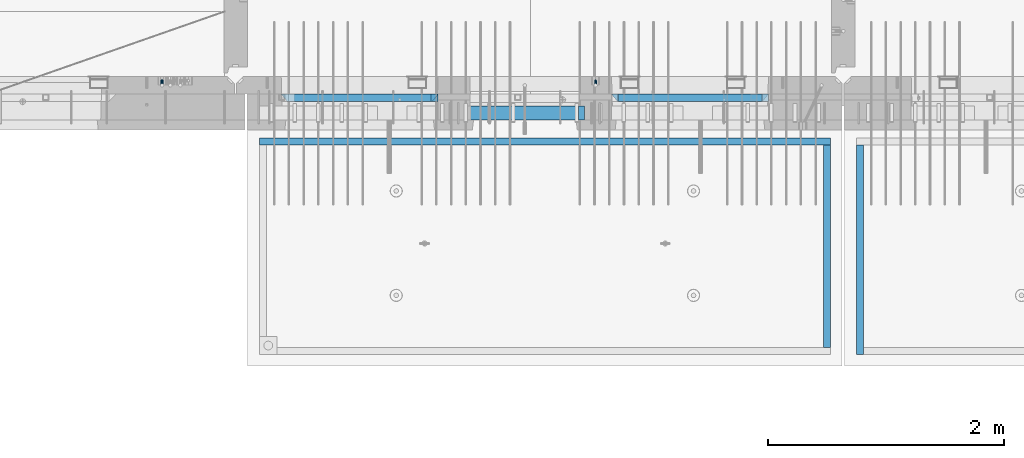
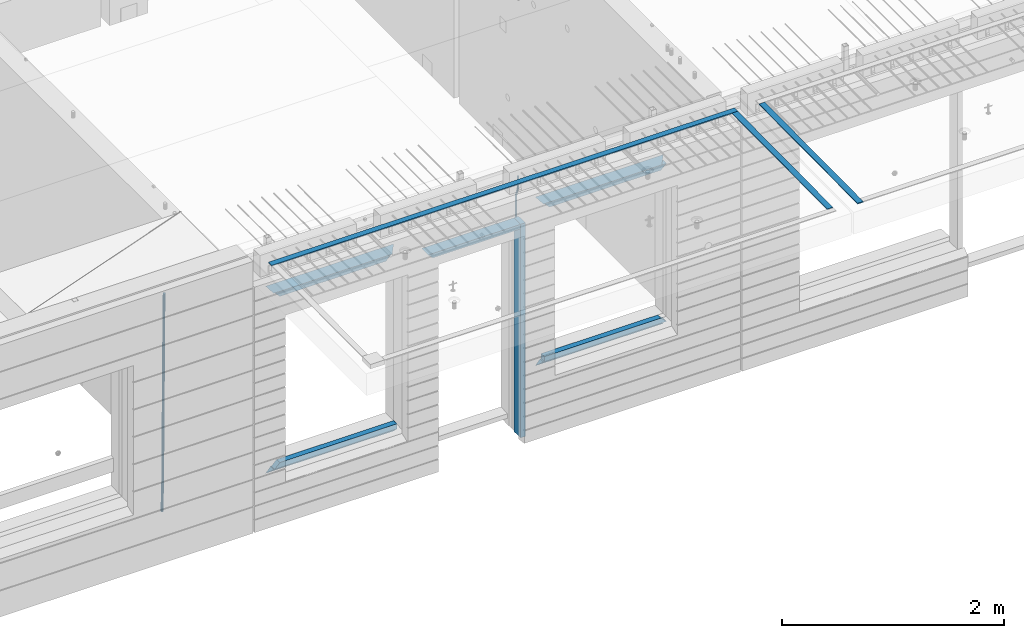
# One storey, part 91 of 341: 15 beams, 4 elements without a shape of their own.
"""IFC2X3 building model written with IfcOpenShell, lengths in millimetres."""

from ifc_helpers import new_model, si_unit, frame, origin_with_axes, place, context, subcontext, project, spatial, faceted_brep, material, type_object, element, aggregate, save


model = new_model("IFC2X3")

# Units and contexts
model_context = context("Model", 3, precision=1e-05, world=origin_with_axes())
body_context = subcontext(model_context, "Body", "Model", "MODEL_VIEW")
ifc_project = project(units=[si_unit("LENGTHUNIT", "METRE", prefix="MILLI"), si_unit("AREAUNIT", "SQUARE_METRE"), si_unit("VOLUMEUNIT", "CUBIC_METRE"), si_unit("MASSUNIT", "GRAM", prefix="KILO"), si_unit("TIMEUNIT", "SECOND"), si_unit("PLANEANGLEUNIT", "RADIAN"), si_unit("SOLIDANGLEUNIT", "STERADIAN"), si_unit("THERMODYNAMICTEMPERATUREUNIT", "DEGREE_CELSIUS"), si_unit("LUMINOUSINTENSITYUNIT", "LUMEN")], contexts=[model_context])

# Site, building, storey
site_placement = place(None, origin_with_axes())
site = spatial("IfcSite", under=ifc_project, at=site_placement, CompositionType="ELEMENT")
building_placement = place(site_placement, origin_with_axes())
building = spatial("IfcBuilding", under=site, at=building_placement, CompositionType="ELEMENT")
storey_placement = place(building_placement, origin_with_axes())
storey = spatial("IfcBuildingStorey", under=building, at=storey_placement, Name="5", CompositionType="ELEMENT", Elevation=0.0)

# Assembly, beam
assembly_1_placement = place(storey_placement, origin_with_axes())
assembly_1 = element("IfcElementAssembly", 1, at=assembly_1_placement, inside=storey, AssemblyPlace="NOTDEFINED", PredefinedType="REINFORCEMENT_UNIT")
ifc_material_1 = material()
beam_type_1 = type_object("IfcBeamType", Name="D20", PredefinedType="NOTDEFINED")
beam_1_placement = place(assembly_1_placement, frame((19710.0073333522, 7925.0, 96407.5000058722), z_axis=(0.000415599999849905, 0.999999913638203, 4.76000000899737e-07), x_axis=(0.0, 0.0, -1.0)))
beam_1 = element("IfcBeam", 2, at=beam_1_placement, type_object=beam_type_1, material=ifc_material_1, Name="JM20", ObjectType="D20", context=body_context, shape_type="Brep", body=[
    faceted_brep([(0.0, -10.0, 0.0), (-4.19531716033816e-08, -7.07106781186667, -7.07106781187031), (113.248091332178, -7.0710684840451, -7.0710678117357), (113.248091314759, -10.0000006713562, -2.51020537689328e-10), (0.0, 0.0, -10.0), (113.248091374131, -6.72178430249915e-07, -9.99999999986903), (4.196772351861e-08, 7.07106781186303, -7.07106781186667), (113.248091416113, 7.07106713968824, -7.07106781173934), (0.0, 10.0, 0.0), (113.248091433488, 9.99999932782521, 1.30967237055302e-10), (4.196772351861e-08, 7.07106781185939, 7.07106781185939), (113.248091416113, 7.0710671396846, 7.071067811994), (0.0, 0.0, 10.0), (113.248091374131, -6.72174792271107e-07, 10.0000000001273), (-4.19531716033816e-08, -7.07106781187031, 7.07106781185939), (113.248091332178, -7.0710684840451, 7.071067811994), (130.699843527167, -7.06993249763036, -4.33745683788584), (128.538066582521, -9.99900540317321, 2.39499413731755), (131.594536475241, 0.00119355250353692, -7.12624594330919), (130.698046432328, 7.07220300913468, -4.33773834422391), (128.535525107087, 10.0009944322555, 2.39459602660281), (126.373748162892, 7.07192152754578, 9.1270470011732), (125.479055214906, 0.000795477419160306, 11.9158361066184), (126.37554525779, -7.07021397921199, 9.12732850753673), (240.336258550378, -7.05529970173666, 30.8729495437874), (238.174481606227, -9.98437260450009, 37.6054005176375), (241.230951498423, 0.0158263482953771, 28.0841604381058), (240.334461455612, 7.0868358050102, 30.8726680369582), (238.171940130502, 10.0156272283348, 37.6050024077231), (236.010163186409, 7.08655432384694, 44.3374533824244), (235.115470238379, 0.0154282738185429, 47.1262424881097), (236.011960281176, -7.05558118289991, 44.3377348892536), (253.461915329972, -7.05444528127919, 32.9289287376414), (253.46191532613, -9.98337746617108, 39.9999965521893), (253.461915339081, 0.0166225284556276, 29.9999965443676), (253.461915348205, 7.08769034247234, 32.9289287273205), (253.461915352003, 10.0166225357716, 39.9999965370152), (253.461915348293, 7.08769035281148, 47.0710643509774), (253.461915339183, 0.0166225430875784, 49.999996544273), (253.46191533003, -7.05444527093641, 47.0710643613093), (1617.47998045172, -7.05444857276962, 32.9289287369675), (1617.47998044467, -9.98338075699212, 39.9999965504549), (1617.47998046874, 0.0166192374708771, 29.9999965449206), (1617.47998048575, 7.08768705096008, 32.9289287291404), (1617.47998049279, 10.0166192430079, 39.9999965393854), (1617.47998048575, 7.08768705878902, 47.071064352871), (1617.47998046874, 0.0166192485448846, 49.9999965449197), (1617.47998045172, -7.05444856494069, 47.0710643606981)], [[[0, 1, 2, 3]], [[1, 4, 5, 2]], [[4, 6, 7, 5]], [[6, 8, 9, 7]], [[8, 10, 11, 9]], [[10, 12, 13, 11]], [[12, 14, 15, 13]], [[14, 0, 3, 15]], [[14, 12, 10, 8, 6, 4, 1, 0]], [[3, 2, 16, 17]], [[2, 5, 18, 16]], [[5, 7, 19, 18]], [[7, 9, 20, 19]], [[9, 11, 21, 20]], [[11, 13, 22, 21]], [[13, 15, 23, 22]], [[15, 3, 17, 23]], [[17, 16, 24, 25]], [[16, 18, 26, 24]], [[18, 19, 27, 26]], [[19, 20, 28, 27]], [[20, 21, 29, 28]], [[21, 22, 30, 29]], [[22, 23, 31, 30]], [[23, 17, 25, 31]], [[25, 24, 32, 33]], [[24, 26, 34, 32]], [[26, 27, 35, 34]], [[27, 28, 36, 35]], [[28, 29, 37, 36]], [[29, 30, 38, 37]], [[30, 31, 39, 38]], [[31, 25, 33, 39]], [[33, 32, 40, 41]], [[32, 34, 42, 40]], [[34, 35, 43, 42]], [[35, 36, 44, 43]], [[36, 37, 45, 44]], [[37, 38, 46, 45]], [[38, 39, 47, 46]], [[39, 33, 41, 47]], [[42, 43, 44, 45, 46, 47, 41, 40]]]),
])

assembly_2_placement = place(storey_placement, origin_with_axes())
assembly_2 = element("IfcElementAssembly", 3, at=assembly_2_placement, inside=storey, AssemblyPlace="NOTDEFINED", PredefinedType="REINFORCEMENT_UNIT")
beam_type_2 = type_object("IfcBeamType", Name="D25", PredefinedType="NOTDEFINED")
beam_2_placement = place(assembly_2_placement, frame((16034.9999999961, 7965.00000227913, 93990.0), z_axis=(0.00020576299992186, -0.999642804629538, -0.0267249099901004), x_axis=(-4.30000201928125e-08, -0.0267249099948059, 0.999642825806181)))
beam_2 = element("IfcBeam", 4, at=beam_2_placement, type_object=beam_type_2, material=ifc_material_1, Name="JM25", ObjectType="D25", context=body_context, shape_type="Brep", body=[
    faceted_brep([(-7.41420080885291e-08, -12.5, -3.63797880709171e-12), (-6.42030499875546e-08, -10.8253175473074, -6.25000000000364), (60.4103898235917, -10.8253175318459, -6.2499999938409), (60.4103898269532, -12.4999999845422, 6.16273609921336e-09), (-3.70782800018787e-08, -6.25000000000364, -10.8253175473074), (60.4103898202884, -6.24999998454587, -10.8253175411446), (-1.45519152283669e-11, -3.63797880709171e-12, -12.5), (60.4103898179019, 1.54577719513327e-08, -12.4999999938373), (3.70637280866504e-08, 6.25, -10.8253175473074), (60.410389817087, 6.25000001545777, -10.825317541141), (6.42030499875546e-08, 10.8253175473001, -6.25000000000364), (60.410389818062, 10.8253175627578, -6.24999999383726), (7.41420080885291e-08, 12.4999999999927, 0.0), (60.4103898205503, 12.5000000154541, 6.16273609921336e-09), (6.42176019027829e-08, 10.8253175473001, 6.24999999999636), (60.4103898238973, 10.8253175627651, 6.2500000061591), (3.70928319171071e-08, 6.24999999999636, 10.8253175473037), (60.4103898272151, 6.25000001546141, 10.8253175534664), (1.45519152283669e-11, -3.63797880709171e-12, 12.4999999999964), (60.4103898296162, 1.54541339725256e-08, 12.5000000061591), (-3.7049176171422e-08, -6.25000000000364, 10.8253175473001), (60.4103898304165, -6.24999998454587, 10.8253175534701), (-6.41884980723262e-08, -10.8253175473074, 6.25), (60.4103898294561, -10.8253175318459, 6.25000000616637), (61.0324985728803, -10.8253175316895, -6.24999999377542), (60.991802792938, -12.4999999843931, 6.22458173893392e-09), (61.0622854283865, -6.24999998437852, -10.8253175410755), (61.0731819955545, 1.5628756955266e-08, -12.4999999937718), (61.0622685480339, 6.25000001562512, -10.8253175410791), (61.032469335245, 10.8253175629216, -6.24999999377178), (60.9917690322181, 12.5000000156033, 6.22458173893392e-09), (60.9510732522613, 10.8253175629034, 6.25000000621731), (60.9212863967696, 6.25000001558874, 10.8253175535247), (60.9103898296162, 1.55814632307738e-08, 12.5000000062137), (60.9213032771368, -6.24999998441126, 10.8253175535174), (60.9511024898966, -10.8253175317113, 6.25000000621731), (61.6545545670233, -10.8253158516927, -6.24189838219536), (61.573166454793, -12.499998414296, 0.00757164385504439), (61.7141257553885, -6.24999822394238, -10.8168280205282), (61.7359179680789, 1.80548886419274e-06, -12.491368569139), (61.7140919992817, 6.25000177601396, -10.8168282403167), (61.6544960997562, 10.8253192428383, -6.2418987628771), (61.5730989426083, 12.5000015856094, 0.0075712042817031), (61.4917108303925, 10.8253190230062, 6.25704123032847), (61.4321396420273, 6.25000139525582, 10.8319708686649), (61.4103474293224, 1.36582457344048e-06, 12.5065114172721), (61.4321733981196, -6.24999860470052, 10.8319710884571), (61.4917692976451, -10.8253160715249, 6.25704161101385), (176.524302641745, -10.8250056210964, -4.74584321979273), (176.442914529529, -12.4996881836996, 1.50362680625403), (176.583873830095, -6.24968799334965, -9.3207728581292), (176.605666042786, 0.000312036081595579, -10.9953134067364), (176.583840074018, 6.25031200660669, -9.32077307791769), (176.524244174492, 10.8256294734347, -4.74584360047811), (176.44284701733, 12.5003118162058, 1.50362636668069), (176.361458905099, 10.8256292535989, 7.75309639272746), (176.301887716749, 6.25031162585219, 12.3280260310676), (176.280095504058, 0.000311596420942806, 14.0025665796711), (176.301921472827, -6.24968837410415, 12.3280262508561), (176.361517372367, -10.8250058409321, 7.75309677341284), (177.085397012124, -10.8250041057399, -4.73853556792164), (176.983633547483, -12.4996867233749, 1.51066909103247), (177.159881729676, -6.24968643771717, -9.31327097355097), (177.187129580227, 0.000313606451527448, -10.987740468332), (177.159839524218, 6.25031356221734, -9.31327130338468), (177.085323910098, 10.8256309887511, -4.73853613920801), (176.983549136537, 12.5003132764905, 1.51066843136869), (176.881785671867, 10.8256306588555, 7.7598730903228), (176.80730095433, 6.25031299082912, 12.3346084959521), (176.780053103794, 0.000312946667690994, 14.0090779907332), (176.807343159802, -6.2496870091054, 12.3346088257895), (176.881858773908, -10.8250044356355, 7.7598736616128), (177.646431799818, -10.8250018318176, -4.72756919822132), (177.524295146417, -12.4996845320202, 1.52123723245313), (177.735828462886, -6.24968410334986, -9.30201312475765), (177.768531371941, 0.00031596292683389, -10.9763759912421), (177.735777808921, 6.25031589654827, -9.30201361973741), (177.646344064575, 10.8256332626152, -4.72757005553649), (177.524193838486, 12.5003154677688, 1.52123624250817), (177.402057185071, 10.8256327675663, 7.77004267317898), (177.312660521988, 6.2503150390985, 12.3444865997226), (177.279957612933, 0.00031497282179771, 14.0188494661961), (177.312711175953, -6.24968496079964, 12.3444870946951), (177.402144920314, -10.8250023268702, 7.77004353049415), (299.377443161706, -10.8245084454466, -2.34813158632096), (299.255306508276, -12.4991911456491, 3.90067484435349), (299.466839824803, -6.24919071697514, -6.92257551286093), (299.499542733873, 0.0008093492979242, -8.59693837933446), (299.466789170867, 6.250809282923, -6.92257600783341), (299.377355426492, 10.8261266489935, -2.34813244364341), (299.255205200388, 12.5008088541435, 3.90067385440125), (299.133068546944, 10.826126153941, 10.1494802850757), (299.043671883861, 6.25080842546959, 14.7239242116229), (299.010968974762, 0.000808359200163977, 16.3982870780892), (299.043722537797, -6.24919157442127, 14.7239247065918), (299.133156282158, -10.8245089404954, 10.1494811423981), (299.98561436501, -10.8245059804758, -2.33624385599614), (299.97179243555, -12.4991882411778, 3.91467976726199), (299.995742293278, -6.24918857328521, -6.91223722345239), (299.999447243041, 0.000811375455668895, -8.58716690387519), (299.995736475976, 6.25081142679483, -6.91223684201032), (299.985604289133, 10.8261291142808, -2.33624319533556), (299.971750386685, 12.5008117588586, 3.91467993563856), (299.957928457196, 10.8261294971744, 10.1656035610831), (299.947800528913, 6.25081208998381, 14.7415969285394), (299.944095579151, 0.00081214124293183, 16.4165266089549), (299.947806346216, -6.24918791008895, 14.7415965471009), (299.957938533058, -10.8245055975785, 10.1656029004225), (300.593832239858, -10.8245078794353, -2.34543881707941), (300.688302931099, -12.4991904788549, 3.90384712594823), (300.524685350189, -6.24919022474205, -6.92023371784308), (300.499390115292, 0.000809814544481924, -8.59472497713432), (300.524724372954, 6.25080977519247, -6.92023401429469), (300.593899829313, 10.8261272150703, -2.34543933054374), (300.688380976673, 12.5008095210287, 3.90384653304136), (300.782851667915, 10.8261269216127, 10.1531324760799), (300.851998557599, 6.25080926691589, 14.7279273768363), (300.877293792495, 0.000809227632998955, 16.4024186361276), (300.851959534804, -6.24919073302226, 14.7279276732806), (300.782784078474, -10.8245081728965, 10.153132989537), (2293.32930409742, -10.8307295605009, -32.4713622331001), (2293.42377478865, -12.5054121599169, -26.2220762900724), (2293.26015720774, -6.2554119058077, -37.0461571338565), (2293.23486197284, -0.00541186651753378, -38.7206483931477), (2293.26019623051, 6.24458809413409, -37.0461574303008), (2293.32937168686, 10.8199055340046, -32.4713627465644), (2293.42385283421, 12.4945878399631, -26.2220768829684), (2293.51832352545, 10.8199052405434, -19.972790939948), (2293.58747041514, 6.24458758585388, -15.3979960391844), (2293.61276565003, -0.00541245343265473, -13.7235047798931), (2293.58743139236, -6.25541241408428, -15.3979957427327), (2293.51825593603, -10.8307298539585, -19.9727904264691), (2294.0420846676, -10.8307317859326, -32.4821379598216), (2294.03681932652, -12.5054140739521, -26.2313442200393), (2294.06778164886, -6.2554144273563, -37.0583666982457), (2294.10702478497, -0.00541458957013674, -38.7338336404937), (2294.14929890928, 6.24458531819619, -37.0595987724118), (2294.18327670435, 10.8199028679592, -32.4842719748667), (2294.1998538474, 12.4945854171456, -26.2338083683717), (2294.19458850632, 10.819903129126, -19.9830146285858), (2294.16889152506, 6.24458577054975, -15.4067858901581), (2294.12964838895, -0.0054140672327776, -13.7313189479173), (2294.08737426462, -6.2554139749991, -15.4055538159919), (2294.05339646956, -10.8307315247621, -19.9808806135297), (2294.75482297382, -10.84002603931, -32.4726521173216), (2294.64982751427, -12.513407826169, -26.2231856868602), (2294.87535820232, -6.26594539088183, -37.0476186524102), (2294.97913588268, -0.0167870967634371, -38.7222267036377), (2295.0383488692, 6.23299192477134, -37.0477663960555), (2295.03713108998, 10.8087684320271, -32.4729080168181), (2294.97580884799, 12.4844668051373, -26.2234811741473), (2294.87081338844, 10.8110850182784, -19.9740147436787), (2294.7502781599, 6.23700436985018, -15.3990482086047), (2294.64650047956, -0.0121539242718427, -13.7244401573698), (2294.58728749304, -6.26193294580662, -15.3989004649666), (2294.58850527227, -10.8377094530588, -19.9737588441894), (2316.44667268227, -11.1228921988077, -32.1839550346631), (2316.34167722271, -12.7962739856739, -25.9344886042054), (2316.56720791078, -6.54881155039038, -36.7589215697517), (2316.67098559113, -0.299653256264719, -38.4335296209792), (2316.73019857766, 5.95012576527006, -36.759069313397), (2316.72898079845, 10.5259022725259, -32.1842109341669), (2316.66765855643, 12.2016006456361, -25.9347840914961), (2316.56266309689, 10.5282188587698, -19.6853176610275), (2316.44212786836, 5.95413821035254, -15.1103511259389), (2316.33835018802, -0.295020083769487, -13.4357430747186), (2316.27913720149, -6.54479910530426, -15.1102033823008), (2316.28035498071, -11.1205756125637, -19.685061761531), (2317.13234804722, -11.1318335458927, -32.1748293731798), (2317.04181141085, -12.8054038787741, -25.9251705100723), (2317.2154741603, -6.5572650749491, -36.7502937866229), (2317.26891617525, -0.307450393454928, -38.4255717558117), (2317.27835434731, 5.94297770185585, -36.7517739018112), (2317.24125972588, 10.5192220504723, -32.1773930078925), (2317.16757178486, 12.1950816748285, -25.9281307404563), (2317.0770351485, 10.5215113419545, -19.6784718773561), (2316.99390903539, 5.94694287101083, -15.1030074639057), (2316.94046702047, -0.302871810494253, -13.4277294947169), (2316.9310288484, -6.55329990579412, -15.1015273487101), (2316.96812346982, -11.1295442544142, -19.6759082426288), (2317.81808136747, -11.1298054502913, -32.1659056455355), (2317.74200467508, -12.803315894289, -25.9160547315114), (2317.86379538118, -6.55536082026447, -36.7418676070083), (2317.8668976831, -0.305700748642266, -38.417815303761), (2317.82655701396, 5.94458339541234, -36.7446799039099), (2317.75358262347, 10.5207330230332, -32.1707766866384), (2317.66752794063, 12.1965725370646, -25.9216793252963), (2317.59145124823, 10.5230620930706, -19.6718284112721), (2317.54573723453, 5.94861746304377, -15.0958664497994), (2317.54263493262, -0.301042608574789, -13.4199187530394), (2317.58297560175, -6.55132675263303, -15.0930541529051), (2317.65594999224, -11.1274763802539, -19.6669573701693), (2417.81884292323, -10.831603083323, -30.8687911350135), (2417.74276623082, -12.505113527317, -24.618940220982), (2417.86455693691, -6.25715845329614, -35.4447530964935), (2417.86765923884, -0.00749838167394046, -37.1207007932499), (2417.82731856969, 6.24278576237703, -35.4475653933878), (2417.75434417921, 10.8189353900088, -30.8736621761236), (2417.66828949639, 12.494774904033, -24.6245648147851), (2417.59221280397, 10.8212644600353, -18.3747139007501), (2417.54649879028, 6.2468198300121, -13.79875193927), (2417.54339648837, -0.00284024161010166, -12.1228042425173), (2417.5837371575, -6.25312438566107, -13.795939642383), (2417.65671154798, -10.8292740132893, -18.3698428596399)], [[[0, 1, 2, 3]], [[1, 4, 5, 2]], [[4, 6, 7, 5]], [[6, 8, 9, 7]], [[8, 10, 11, 9]], [[10, 12, 13, 11]], [[12, 14, 15, 13]], [[14, 16, 17, 15]], [[16, 18, 19, 17]], [[18, 20, 21, 19]], [[20, 22, 23, 21]], [[22, 0, 3, 23]], [[22, 20, 18, 16, 14, 12, 10, 8, 6, 4, 1, 0]], [[3, 2, 24, 25]], [[2, 5, 26, 24]], [[5, 7, 27, 26]], [[7, 9, 28, 27]], [[9, 11, 29, 28]], [[11, 13, 30, 29]], [[13, 15, 31, 30]], [[15, 17, 32, 31]], [[17, 19, 33, 32]], [[19, 21, 34, 33]], [[21, 23, 35, 34]], [[23, 3, 25, 35]], [[25, 24, 36, 37]], [[24, 26, 38, 36]], [[26, 27, 39, 38]], [[27, 28, 40, 39]], [[28, 29, 41, 40]], [[29, 30, 42, 41]], [[30, 31, 43, 42]], [[31, 32, 44, 43]], [[32, 33, 45, 44]], [[33, 34, 46, 45]], [[34, 35, 47, 46]], [[35, 25, 37, 47]], [[37, 36, 48, 49]], [[36, 38, 50, 48]], [[38, 39, 51, 50]], [[39, 40, 52, 51]], [[40, 41, 53, 52]], [[41, 42, 54, 53]], [[42, 43, 55, 54]], [[43, 44, 56, 55]], [[44, 45, 57, 56]], [[45, 46, 58, 57]], [[46, 47, 59, 58]], [[47, 37, 49, 59]], [[49, 48, 60, 61]], [[48, 50, 62, 60]], [[50, 51, 63, 62]], [[51, 52, 64, 63]], [[52, 53, 65, 64]], [[53, 54, 66, 65]], [[54, 55, 67, 66]], [[55, 56, 68, 67]], [[56, 57, 69, 68]], [[57, 58, 70, 69]], [[58, 59, 71, 70]], [[59, 49, 61, 71]], [[61, 60, 72, 73]], [[60, 62, 74, 72]], [[62, 63, 75, 74]], [[63, 64, 76, 75]], [[64, 65, 77, 76]], [[65, 66, 78, 77]], [[66, 67, 79, 78]], [[67, 68, 80, 79]], [[68, 69, 81, 80]], [[69, 70, 82, 81]], [[70, 71, 83, 82]], [[71, 61, 73, 83]], [[73, 72, 84, 85]], [[72, 74, 86, 84]], [[74, 75, 87, 86]], [[75, 76, 88, 87]], [[76, 77, 89, 88]], [[77, 78, 90, 89]], [[78, 79, 91, 90]], [[79, 80, 92, 91]], [[80, 81, 93, 92]], [[81, 82, 94, 93]], [[82, 83, 95, 94]], [[83, 73, 85, 95]], [[85, 84, 96, 97]], [[84, 86, 98, 96]], [[86, 87, 99, 98]], [[87, 88, 100, 99]], [[88, 89, 101, 100]], [[89, 90, 102, 101]], [[90, 91, 103, 102]], [[91, 92, 104, 103]], [[92, 93, 105, 104]], [[93, 94, 106, 105]], [[94, 95, 107, 106]], [[95, 85, 97, 107]], [[97, 96, 108, 109]], [[96, 98, 110, 108]], [[98, 99, 111, 110]], [[99, 100, 112, 111]], [[100, 101, 113, 112]], [[101, 102, 114, 113]], [[102, 103, 115, 114]], [[103, 104, 116, 115]], [[104, 105, 117, 116]], [[105, 106, 118, 117]], [[106, 107, 119, 118]], [[107, 97, 109, 119]], [[109, 108, 120, 121]], [[108, 110, 122, 120]], [[110, 111, 123, 122]], [[111, 112, 124, 123]], [[112, 113, 125, 124]], [[113, 114, 126, 125]], [[114, 115, 127, 126]], [[115, 116, 128, 127]], [[116, 117, 129, 128]], [[117, 118, 130, 129]], [[118, 119, 131, 130]], [[119, 109, 121, 131]], [[121, 120, 132, 133]], [[120, 122, 134, 132]], [[122, 123, 135, 134]], [[123, 124, 136, 135]], [[124, 125, 137, 136]], [[125, 126, 138, 137]], [[126, 127, 139, 138]], [[127, 128, 140, 139]], [[128, 129, 141, 140]], [[129, 130, 142, 141]], [[130, 131, 143, 142]], [[131, 121, 133, 143]], [[133, 132, 144, 145]], [[132, 134, 146, 144]], [[134, 135, 147, 146]], [[135, 136, 148, 147]], [[136, 137, 149, 148]], [[137, 138, 150, 149]], [[138, 139, 151, 150]], [[139, 140, 152, 151]], [[140, 141, 153, 152]], [[141, 142, 154, 153]], [[142, 143, 155, 154]], [[143, 133, 145, 155]], [[145, 144, 156, 157]], [[144, 146, 158, 156]], [[146, 147, 159, 158]], [[147, 148, 160, 159]], [[148, 149, 161, 160]], [[149, 150, 162, 161]], [[150, 151, 163, 162]], [[151, 152, 164, 163]], [[152, 153, 165, 164]], [[153, 154, 166, 165]], [[154, 155, 167, 166]], [[155, 145, 157, 167]], [[157, 156, 168, 169]], [[156, 158, 170, 168]], [[158, 159, 171, 170]], [[159, 160, 172, 171]], [[160, 161, 173, 172]], [[161, 162, 174, 173]], [[162, 163, 175, 174]], [[163, 164, 176, 175]], [[164, 165, 177, 176]], [[165, 166, 178, 177]], [[166, 167, 179, 178]], [[167, 157, 169, 179]], [[169, 168, 180, 181]], [[168, 170, 182, 180]], [[170, 171, 183, 182]], [[171, 172, 184, 183]], [[172, 173, 185, 184]], [[173, 174, 186, 185]], [[174, 175, 187, 186]], [[175, 176, 188, 187]], [[176, 177, 189, 188]], [[177, 178, 190, 189]], [[178, 179, 191, 190]], [[179, 169, 181, 191]], [[181, 180, 192, 193]], [[180, 182, 194, 192]], [[182, 183, 195, 194]], [[183, 184, 196, 195]], [[184, 185, 197, 196]], [[185, 186, 198, 197]], [[186, 187, 199, 198]], [[187, 188, 200, 199]], [[188, 189, 201, 200]], [[189, 190, 202, 201]], [[190, 191, 203, 202]], [[191, 181, 193, 203]], [[194, 195, 196, 197, 198, 199, 200, 201, 202, 203, 193, 192]]]),
])
aggregate(assembly_2, [beam_2])

assembly_3_placement = place(storey_placement, origin_with_axes())
assembly_3 = element("IfcElementAssembly", 5, at=assembly_3_placement, inside=storey, AssemblyPlace="NOTDEFINED", PredefinedType="REINFORCEMENT_UNIT")
ifc_material_2 = material(Name="CONCRETE/Concrete_Undefined")
beam_type_3 = type_object("IfcBeamType", PredefinedType="NOTDEFINED")
beam_3_placement = place(assembly_3_placement, frame((21949.9413897781, 7420.05314849477, 96725.6636561746), z_axis=(2.93000000986506e-07, -0.00901322400064496, 0.999959380071525), x_axis=(3.25389999851993e-05, -0.999959379542196, -0.00901322399586982)))
beam_3 = element("IfcBeam", 6, at=beam_3_placement, type_object=beam_type_3, material=ifc_material_2, context=body_context, shape_type="Brep", body=[
    faceted_brep([(2.5465851649642e-11, 29.9999999999982, -4.99999999998545), (-2.91038304567337e-11, 29.9999999999982, 5.0), (1775.16788460852, 30.0000000000036, 5.0), (1775.16788460861, 30.0000000000036, -4.99999999998545), (-2.5465851649642e-11, -30.0000000000018, 5.0), (1775.16788460852, -29.9999999999927, 5.0), (2.72848410531878e-11, -30.0000000000018, -4.99999999998545), (1775.16788460861, -29.9999999999927, -4.99999999998545)], [[[0, 1, 2, 3]], [[1, 4, 5, 2]], [[4, 6, 7, 5]], [[6, 0, 3, 7]], [[5, 7, 3, 2]], [[6, 4, 1, 0]]]),
])
aggregate(assembly_3, [beam_3])

# Assembly, beams
assembly_4_placement = place(storey_placement, origin_with_axes())
assembly_4 = element("IfcElementAssembly", 7, at=assembly_4_placement, inside=storey, AssemblyPlace="NOTDEFINED", PredefinedType="REINFORCEMENT_UNIT")
beam_4_placement = place(assembly_4_placement, frame((21670.0013901233, 7419.93998011425, 96723.2790373904), z_axis=(-5.99999839176643e-09, -0.0089070149978186, 0.99996033175513), x_axis=(-7.26999998800451e-07, -0.999960331754865, -0.00890701499781462)))
beam_4 = element("IfcBeam", 8, at=beam_4_placement, type_object=beam_type_3, material=ifc_material_2, context=body_context, shape_type="Brep", body=[
    faceted_brep([(2.5465851649642e-11, 29.9999999999982, -4.99999999998545), (-2.91038304567337e-11, 29.9999999999982, 5.0), (1714.98205429674, 30.0, 5.00000000001455), (1714.98205429674, 30.0000000000036, -4.99999999998545), (-2.5465851649642e-11, -30.0000000000018, 5.0), (1714.98205429674, -30.0, 5.00000000001455), (2.72848410531878e-11, -30.0000000000018, -4.99999999998545), (1714.98205429674, -29.9999999999964, -4.99999999998545)], [[[0, 1, 2, 3]], [[1, 4, 5, 2]], [[4, 6, 7, 5]], [[6, 0, 3, 7]], [[5, 7, 3, 2]], [[6, 4, 1, 0]]]),
])
beam_5_placement = place(assembly_4_placement, frame((21700.0027302922, 7449.93184428734, 96723.6588442717), z_axis=(0.0, 0.0, 1.0), x_axis=(-0.999999999888168, 1.49249999983396e-05, 9.53000001204034e-07)))
beam_5 = element("IfcBeam", 9, at=beam_5_placement, type_object=beam_type_3, material=ifc_material_2, context=body_context, shape_type="Brep", body=[
    faceted_brep([(2.5465851649642e-11, 29.9999999999982, -4.99999999998545), (-2.91038304567337e-11, 29.9999999999982, 5.0), (4840.00999799337, 29.9999999999991, 5.0), (4840.00999799337, 29.9999999999982, -5.00000000001455), (-2.5465851649642e-11, -30.0000000000018, 5.0), (4840.00999799337, -30.0000000000009, 5.0), (2.72848410531878e-11, -30.0000000000018, -4.99999999998545), (4840.00999799337, -30.0000000000009, -5.0)], [[[0, 1, 2, 3]], [[1, 4, 5, 2]], [[4, 6, 7, 5]], [[6, 0, 3, 7]], [[5, 7, 3, 2]], [[6, 4, 1, 0]]]),
])
aggregate(assembly_4, [beam_4, beam_5])

# Beam
ifc_material_3 = material(Name="CONCRETE/C35/45")
beam_type_4 = type_object("IfcBeamType", PredefinedType="NOTDEFINED")
beam_6_placement = place(assembly_1_placement, frame((17044.9994828029, 7820.0, 96145.0), z_axis=(0.0, 0.0, -1.0), x_axis=(1.0, 0.0, 0.0)))
beam_6 = element("IfcBeam", 10, at=beam_6_placement, type_object=beam_type_4, material=ifc_material_3, Name="SK", context=body_context, shape_type="Brep", body=[
    faceted_brep([(0.0, -30.0, -30.0), (49.817662327685, -30.0, 30.0), (49.817662327685, 30.0, 30.0), (1330.00114440918, -30.0, -30.0), (1280.18348208149, -30.0, 30.0), (1280.18348208149, 30.0, 30.0)], [[[0, 1, 2]], [[1, 0, 3, 4]], [[2, 1, 4, 5]], [[0, 2, 5, 3]], [[4, 3, 5]]]),
])

beam_7_placement = place(assembly_1_placement, frame((17104.9994828029, 7820.0, 96085.0), z_axis=(0.0, 0.0, -1.0), x_axis=(1.0, 0.0, 0.0)))
beam_7 = element("IfcBeam", 11, at=beam_7_placement, type_object=beam_type_4, material=ifc_material_3, Name="SK", context=body_context, shape_type="Brep", body=[
    faceted_brep([(0.0, -30.0, -30.0), (53.0959879499314, -30.0, 24.0540540540678), (54.6888675884184, 30.0, 25.6756756756804), (0.0, 30.0, -30.0), (1210.00114440918, -30.0, -30.0), (1156.90515645927, -30.0, 24.0540540540678), (1155.31227682078, 30.0, 25.6756756756804), (1210.00114440918, 30.0, -30.0)], [[[0, 1, 2, 3]], [[1, 0, 4, 5]], [[2, 1, 5, 6]], [[3, 2, 6, 7]], [[0, 3, 7, 4]], [[6, 5, 4, 7]]]),
])

beam_8_placement = place(assembly_1_placement, frame((18375.0006272121, 7820.0, 94150.0), z_axis=(0.0, 0.0, 1.0), x_axis=(-1.0, 3.00000001838171e-08, 0.0)))
beam_8 = element("IfcBeam", 12, at=beam_8_placement, type_object=beam_type_4, material=ifc_material_3, Name="SK", context=body_context, shape_type="Brep", body=[
    faceted_brep([(0.0, -30.0, 30.0), (-5.28234522789717e-09, 30.0, 30.0), (0.0, -30.0, -30.0), (1280.18348208149, -30.0, 30.0), (1280.18348208149, 30.0, 30.0), (1330.00114440918, -30.0, -30.0)], [[[0, 1, 2]], [[1, 0, 3, 4]], [[2, 1, 4, 5]], [[0, 2, 5, 3]], [[3, 5, 4]]]),
])

beam_9_placement = place(assembly_1_placement, frame((18375.0006272121, 7820.0, 94210.0), z_axis=(0.0, 0.0, 1.0), x_axis=(-1.0, 3.00000001838171e-08, 0.0)))
beam_9 = element("IfcBeam", 13, at=beam_9_placement, type_object=beam_type_4, material=ifc_material_3, Name="SK", context=body_context, shape_type="Brep", body=[
    faceted_brep([(0.0, -30.0, -30.0), (0.0, -30.0, 30.0), (-5.28234522789717e-09, 30.0, 30.0), (0.0, 30.0, -30.0), (4.05405405405327, -30.0, 30.0), (5.67567567567312, 30.0, 30.0), (4.05405405404963, -30.0, 24.0540540540533), (5.67567567567312, 30.0, 25.6756756756804), (1215.31227682077, 30.0, 25.6756756756804), (1270.00114440918, 30.0, -30.0), (1270.00114440918, -30.0, -30.0), (1216.90515645926, -30.0, 24.0540540540678)], [[[0, 1, 2, 3]], [[2, 1, 4, 5]], [[4, 6, 7, 5]], [[3, 2, 5, 7, 8, 9]], [[0, 3, 9, 10]], [[6, 4, 1, 0, 10, 11]], [[7, 6, 11, 8]], [[10, 9, 8, 11]]]),
])

beam_10_placement = place(assembly_1_placement, frame((19845.0006272121, 7820.0, 96145.0), z_axis=(0.0, 0.0, -1.0), x_axis=(1.0, 0.0, 0.0)))
beam_10 = element("IfcBeam", 14, at=beam_10_placement, type_object=beam_type_4, material=ifc_material_3, Name="SK", context=body_context, shape_type="Brep", body=[
    faceted_brep([(0.0, -30.0, -30.0), (49.817662327685, -30.0, 30.0), (49.817662327685, 30.0, 30.0), (1329.99923706055, -30.0, -30.0), (1280.18157473286, -30.0, 30.0), (1280.18157473286, 30.0, 30.0)], [[[0, 1, 2]], [[1, 0, 3, 4]], [[2, 1, 4, 5]], [[0, 2, 5, 3]], [[4, 3, 5]]]),
])

beam_11_placement = place(assembly_1_placement, frame((19905.0006272121, 7820.0, 96085.0), z_axis=(0.0, 0.0, -1.0), x_axis=(1.0, 0.0, 0.0)))
beam_11 = element("IfcBeam", 15, at=beam_11_placement, type_object=beam_type_4, material=ifc_material_3, Name="SK", context=body_context, shape_type="Brep", body=[
    faceted_brep([(0.0, -30.0, -30.0), (53.0959879499314, -30.0, 24.0540540540678), (54.6888675884184, 30.0, 25.6756756756804), (0.0, 30.0, -30.0), (1269.99923706055, -30.0, -30.0), (1211.91971158142, -30.0, 24.0540540540533), (1210.17732581704, 30.0, 25.6756756756804), (1269.99923706055, 30.0, -30.0)], [[[0, 1, 2, 3]], [[1, 0, 4, 5]], [[2, 1, 5, 6]], [[3, 2, 6, 7]], [[0, 3, 7, 4]], [[6, 5, 4, 7]]]),
])

beam_12_placement = place(assembly_1_placement, frame((21174.9998642727, 7820.0, 94350.0), z_axis=(0.0, 0.0, 1.0), x_axis=(-1.0, 3.00000001838171e-08, 0.0)))
beam_12 = element("IfcBeam", 16, at=beam_12_placement, type_object=beam_type_4, material=ifc_material_3, Name="SK", context=body_context, shape_type="Brep", body=[
    faceted_brep([(1280.18157473286, -30.0, 30.0), (1329.99923706055, -30.0, -30.0), (1280.18157473286, 30.0, 30.0), (0.0, -30.0, -30.0), (49.817662327685, 30.0, 30.0), (49.817662327685, -30.0, 30.0)], [[[0, 1, 2]], [[3, 4, 2, 1]], [[4, 5, 0, 2]], [[5, 3, 1, 0]], [[3, 5, 4]]]),
])

beam_13_placement = place(assembly_1_placement, frame((21174.9998642727, 7820.0, 94410.0), z_axis=(0.0, 0.0, 1.0), x_axis=(-1.0, 3.00000001838171e-08, 0.0)))
beam_13 = element("IfcBeam", 17, at=beam_13_placement, type_object=beam_type_4, material=ifc_material_3, Name="SK", context=body_context, shape_type="Brep", body=[
    faceted_brep([(1269.99923706055, -30.0, -30.0), (1269.99923706055, 30.0, -30.0), (1269.99923706055, 30.0, 25.6756756756804), (1269.99923706055, -30.0, 24.0540540540678), (0.0, -30.0, -30.0), (0.0, 30.0, -30.0), (59.8219112435072, 30.0, 25.6756756756804), (58.0795254791192, -30.0, 24.0540540540533)], [[[0, 1, 2, 3]], [[4, 5, 1, 0]], [[2, 1, 5, 6]], [[3, 2, 6, 7]], [[0, 3, 7, 4]], [[6, 5, 4, 7]]]),
])

ifc_material_4 = material(Name="TIMBER")
beam_type_5 = type_object("IfcBeamType", Name="50X120", PredefinedType="NOTDEFINED")
beam_14_placement = place(assembly_1_placement, frame((18604.9998642727, 7690.0, 96080.0), z_axis=(0.0, 0.0, -1.0), x_axis=(1.0, 0.0, 0.0)))
beam_14 = element("IfcBeam", 18, at=beam_14_placement, type_object=beam_type_5, material=ifc_material_4, ObjectType="50X120", context=body_context, shape_type="Brep", body=[
    faceted_brep([(1009.99961853027, -60.0, 25.0), (1009.99961853027, -60.0, -25.0), (1009.99961853027, 60.0, -25.0), (1009.99961853027, 60.0, 25.0), (50.0000000000036, -60.0, 25.0), (0.0, -60.0, -25.0), (0.0, 60.0, -25.0), (50.0000000000036, 60.0, 25.0)], [[[0, 1, 2, 3]], [[1, 0, 4, 5]], [[2, 1, 5, 6]], [[3, 2, 6, 7]], [[0, 3, 7, 4]], [[6, 5, 4, 7]]]),
])

beam_15_placement = place(assembly_1_placement, frame((19589.9994828029, 7690.0, 96105.0), z_axis=(-1.0, 3.00000001838171e-08, 0.0), x_axis=(0.0, 0.0, -1.0)))
beam_15 = element("IfcBeam", 19, at=beam_15_placement, type_object=beam_type_5, material=ifc_material_4, ObjectType="50X120", context=body_context, shape_type="Brep", body=[
    faceted_brep([(0.0, 60.0, -25.0), (0.0, 60.0, 25.0), (2345.0, 60.0, 25.0), (2345.0, 60.0, -25.0), (0.0, -60.0, 25.0), (2345.0, -60.0, 25.0), (0.0, -60.0, -25.0), (2345.0, -60.0, -25.0)], [[[0, 1, 2, 3]], [[1, 4, 5, 2]], [[4, 6, 7, 5]], [[6, 0, 3, 7]], [[5, 7, 3, 2]], [[6, 4, 1, 0]]]),
])

aggregate(assembly_1, [beam_14, beam_15, beam_1, beam_6, beam_7, beam_8, beam_9, beam_10, beam_11, beam_12, beam_13])

save(model, "model.ifc")
